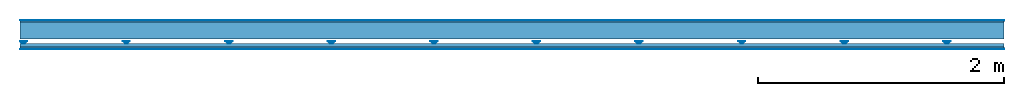
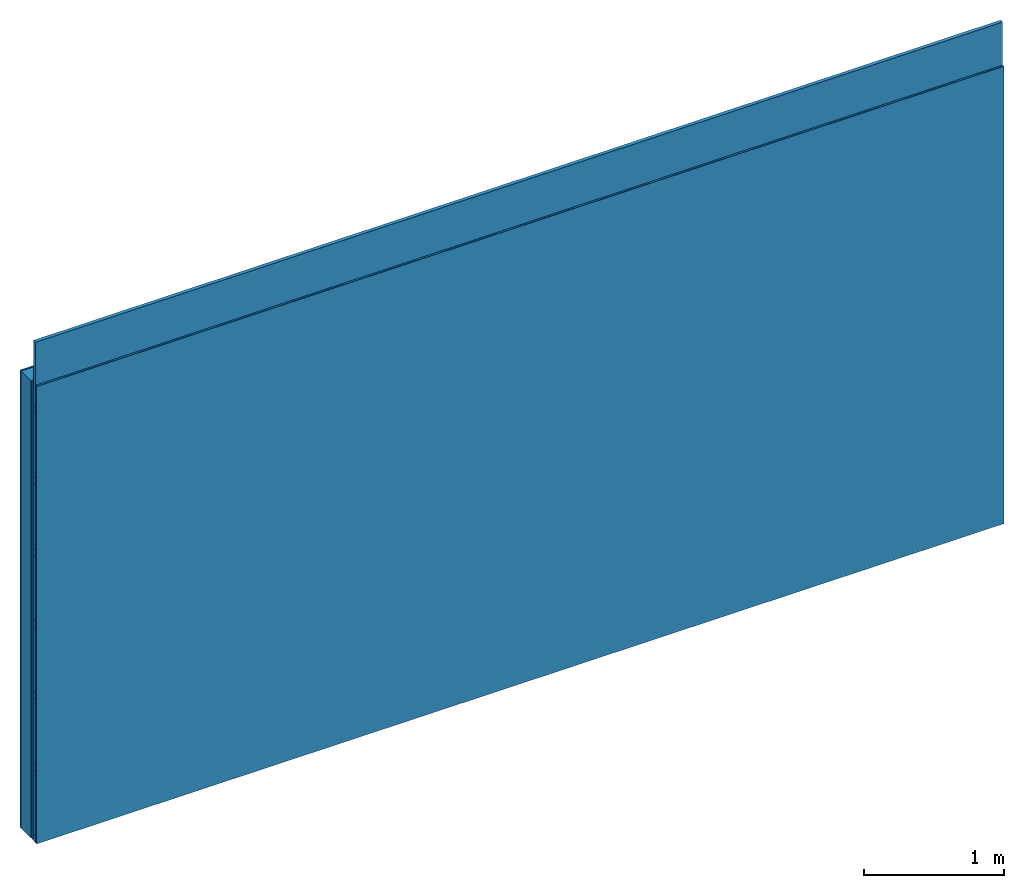
# One storey: 4 members, 4 plates, 1 element without a shape of its own.
"""IFC4 building model written with IfcOpenShell, lengths in metres."""

from ifc_helpers import new_model, si_unit, derived_unit, direction, frame, frame_2d, origin, origin_with_axes, place, context, project, spatial, polyline, rectangle, outline, extrude, material, layer, layer_set, type_object, element, aggregate, save


model = new_model("IFC4")

# Units and contexts
plan_context = context("Plan", 3, precision=1e-05, world=origin(), true_north=direction((0.0, 1.0)))
model_context = context("Model", 3, precision=1e-05, world=origin(), true_north=direction((0.0, 1.0)))
ifc_project = project(units=[si_unit("LENGTHUNIT", "METRE"), derived_unit("SOUNDPRESSUREUNIT", [(si_unit("PRESSUREUNIT", "PASCAL", prefix="MICRO"), 0)]), si_unit("ENERGYUNIT", "JOULE", prefix="MEGA"), si_unit("MASSUNIT", "GRAM", prefix="KILO"), derived_unit("THERMALTRANSMITTANCEUNIT", [(si_unit("POWERUNIT", "WATT"), 1), (si_unit("AREAUNIT", "SQUARE_METRE"), -1), (si_unit("THERMODYNAMICTEMPERATUREUNIT", "KELVIN"), -1)]), derived_unit("AREADENSITYUNIT", [(si_unit("MASSUNIT", "GRAM", prefix="KILO"), 1), (si_unit("AREAUNIT", "SQUARE_METRE"), -1)]), derived_unit("USERDEFINED", [(si_unit("ENERGYUNIT", "JOULE", prefix="MEGA"), 1), (si_unit("AREAUNIT", "SQUARE_METRE"), -1)])], contexts=[plan_context, model_context])

# Site, building, storey
site = spatial("IfcSite", under=ifc_project)
building_placement = place(None, origin())
building = spatial("IfcBuilding", under=site, at=building_placement)
storey_placement = place(building_placement, origin())
storey = spatial("IfcBuildingStorey", under=building, at=storey_placement)

# Wall, members, plates
ifc_material_1 = material(Category="04.001")
ifc_layer_1 = layer(ifc_material_1, 0.003, Name="Surface")
ifc_material_2 = material(Name="Plasterboard type A", Category="03.008")
ifc_layer_2 = layer(ifc_material_2, 0.0125, Name="1st layer")
ifc_material_3 = material(Name="of the art")
ifc_layer_3 = layer(ifc_material_3, 0.0, Name="Bond")
ifc_layer_4 = layer(None, 0.14, Name="Support")
ifc_layer_5 = layer(None, 0.036, Name="Coupling")
ifc_layer_6 = layer(None, 0.03, Name="Battens / profiles")
ifc_material_4 = material(Name="DFH2IR Knauf Diamant hard- plasterboard", Category="03.007")
ifc_layer_7 = layer(ifc_material_4, 0.015, Name="Covering 1st layer")
ifc_layer_8 = layer(ifc_material_1, 0.003, Name="Surface")
ifc_layer_set = layer_set([ifc_layer_1, ifc_layer_2, ifc_layer_3, ifc_layer_4, ifc_layer_5, ifc_layer_6, ifc_layer_7, ifc_layer_8])
wall_type = type_object("IfcWallType", Name="C0378", PredefinedType="NOTDEFINED", material=ifc_layer_set)
wall_placement = place(None, frame((0.0, 0.0, 0.0), z_axis=(0.0, -1.0, 0.0), x_axis=(1.0, 0.0, 0.0)))
wall = element("IfcWall", 1, at=wall_placement, inside=storey, type_object=wall_type, material=ifc_layer_set, Name="Wall #1")
ifc_material_5 = material(Name="Solid timber panel")
member_1_placement = place(wall_placement, origin())
member_1 = element("IfcMember", 2, at=member_1_placement, material=ifc_material_5, Name="Support", context=plan_context, shape_type="SweptSolid", body=[
    extrude(rectangle(XDim=1.0, YDim=0.14, at=frame_2d((0.5, 0.07), x_axis=(1.0, 0.0))), frame((0.0, 4.0, 0.0155), z_axis=(0.0, -1.0, 0.0), x_axis=(1.0, 0.0, 0.0)), (0.0, 0.0, 1.0), 4.0),
    extrude(rectangle(XDim=1.0, YDim=0.14, at=frame_2d((0.5, 0.07), x_axis=(1.0, 0.0))), frame((1.0, 4.0, 0.0155), z_axis=(0.0, -1.0, 0.0), x_axis=(1.0, 0.0, 0.0)), (0.0, 0.0, 1.0), 4.0),
    extrude(rectangle(XDim=1.0, YDim=0.14, at=frame_2d((0.5, 0.07), x_axis=(1.0, 0.0))), frame((2.0, 4.0, 0.0155), z_axis=(0.0, -1.0, 0.0), x_axis=(1.0, 0.0, 0.0)), (0.0, 0.0, 1.0), 4.0),
    extrude(rectangle(XDim=1.0, YDim=0.14, at=frame_2d((0.5, 0.07), x_axis=(1.0, 0.0))), frame((3.0, 4.0, 0.0155), z_axis=(0.0, -1.0, 0.0), x_axis=(1.0, 0.0, 0.0)), (0.0, 0.0, 1.0), 4.0),
    extrude(rectangle(XDim=1.0, YDim=0.14, at=frame_2d((0.5, 0.07), x_axis=(1.0, 0.0))), frame((4.0, 4.0, 0.0155), z_axis=(0.0, -1.0, 0.0), x_axis=(1.0, 0.0, 0.0)), (0.0, 0.0, 1.0), 4.0),
    extrude(rectangle(XDim=1.0, YDim=0.14, at=frame_2d((0.5, 0.07), x_axis=(1.0, 0.0))), frame((5.0, 4.0, 0.0155), z_axis=(0.0, -1.0, 0.0), x_axis=(1.0, 0.0, 0.0)), (0.0, 0.0, 1.0), 4.0),
    extrude(rectangle(XDim=1.0, YDim=0.14, at=frame_2d((0.5, 0.07), x_axis=(1.0, 0.0))), frame((6.0, 4.0, 0.0155), z_axis=(0.0, -1.0, 0.0), x_axis=(1.0, 0.0, 0.0)), (0.0, 0.0, 1.0), 4.0),
    extrude(rectangle(XDim=1.0, YDim=0.14, at=frame_2d((0.5, 0.07), x_axis=(1.0, 0.0))), frame((7.0, 4.0, 0.0155), z_axis=(0.0, -1.0, 0.0), x_axis=(1.0, 0.0, 0.0)), (0.0, 0.0, 1.0), 4.0),
])
ifc_material_6 = material()
member_2_placement = place(wall_placement, origin())
member_2 = element("IfcMember", 3, at=member_2_placement, material=ifc_material_6, Name="Coupling", context=plan_context, shape_type="SweptSolid", body=[
    extrude(outline(polyline([(0.0, 0.0), (0.06, 0.0), (0.04, 0.02), (0.02, 0.02), (0.0, 0.0)])), frame((0.0, 4.0, 0.1715), z_axis=(0.0, -1.0, 0.0), x_axis=(1.0, 0.0, 0.0)), (0.0, 0.0, 1.0), 4.0),
    extrude(outline(polyline([(0.0, 0.0), (0.06, 0.0), (0.04, 0.02), (0.02, 0.02), (0.0, 0.0)])), frame((0.834, 4.0, 0.1715), z_axis=(0.0, -1.0, 0.0), x_axis=(1.0, 0.0, 0.0)), (0.0, 0.0, 1.0), 4.0),
    extrude(outline(polyline([(0.0, 0.0), (0.06, 0.0), (0.04, 0.02), (0.02, 0.02), (0.0, 0.0)])), frame((1.668, 4.0, 0.1715), z_axis=(0.0, -1.0, 0.0), x_axis=(1.0, 0.0, 0.0)), (0.0, 0.0, 1.0), 4.0),
    extrude(outline(polyline([(0.0, 0.0), (0.06, 0.0), (0.04, 0.02), (0.02, 0.02), (0.0, 0.0)])), frame((2.502, 4.0, 0.1715), z_axis=(0.0, -1.0, 0.0), x_axis=(1.0, 0.0, 0.0)), (0.0, 0.0, 1.0), 4.0),
    extrude(outline(polyline([(0.0, 0.0), (0.06, 0.0), (0.04, 0.02), (0.02, 0.02), (0.0, 0.0)])), frame((3.336, 4.0, 0.1715), z_axis=(0.0, -1.0, 0.0), x_axis=(1.0, 0.0, 0.0)), (0.0, 0.0, 1.0), 4.0),
    extrude(outline(polyline([(0.0, 0.0), (0.06, 0.0), (0.04, 0.02), (0.02, 0.02), (0.0, 0.0)])), frame((4.17, 4.0, 0.1715), z_axis=(0.0, -1.0, 0.0), x_axis=(1.0, 0.0, 0.0)), (0.0, 0.0, 1.0), 4.0),
    extrude(outline(polyline([(0.0, 0.0), (0.06, 0.0), (0.04, 0.02), (0.02, 0.02), (0.0, 0.0)])), frame((5.004, 4.0, 0.1715), z_axis=(0.0, -1.0, 0.0), x_axis=(1.0, 0.0, 0.0)), (0.0, 0.0, 1.0), 4.0),
    extrude(outline(polyline([(0.0, 0.0), (0.06, 0.0), (0.04, 0.02), (0.02, 0.02), (0.0, 0.0)])), frame((5.838, 4.0, 0.1715), z_axis=(0.0, -1.0, 0.0), x_axis=(1.0, 0.0, 0.0)), (0.0, 0.0, 1.0), 4.0),
    extrude(outline(polyline([(0.0, 0.0), (0.06, 0.0), (0.04, 0.02), (0.02, 0.02), (0.0, 0.0)])), frame((6.672, 4.0, 0.1715), z_axis=(0.0, -1.0, 0.0), x_axis=(1.0, 0.0, 0.0)), (0.0, 0.0, 1.0), 4.0),
    extrude(outline(polyline([(0.0, 0.0), (0.06, 0.0), (0.04, 0.02), (0.02, 0.02), (0.0, 0.0)])), frame((7.506, 4.0, 0.1715), z_axis=(0.0, -1.0, 0.0), x_axis=(1.0, 0.0, 0.0)), (0.0, 0.0, 1.0), 4.0),
])
member_3_placement = place(wall_placement, origin())
member_3 = element("IfcMember", 4, at=member_3_placement, material=ifc_material_6, Name="Battens / profiles", context=plan_context, shape_type="SweptSolid", body=[
    extrude(rectangle(XDim=0.06, YDim=0.03, at=frame_2d((0.03, 0.015), x_axis=(1.0, 0.0))), frame((0.0, 0.0, 0.1915), z_axis=(1.0, 0.0, 0.0), x_axis=(0.0, 1.0, 0.0)), (0.0, 0.0, 1.0), 8.0),
    extrude(rectangle(XDim=0.06, YDim=0.03, at=frame_2d((0.03, 0.015), x_axis=(1.0, 0.0))), frame((0.0, 0.625, 0.1915), z_axis=(1.0, 0.0, 0.0), x_axis=(0.0, 1.0, 0.0)), (0.0, 0.0, 1.0), 8.0),
    extrude(rectangle(XDim=0.06, YDim=0.03, at=frame_2d((0.03, 0.015), x_axis=(1.0, 0.0))), frame((0.0, 1.25, 0.1915), z_axis=(1.0, 0.0, 0.0), x_axis=(0.0, 1.0, 0.0)), (0.0, 0.0, 1.0), 8.0),
    extrude(rectangle(XDim=0.06, YDim=0.03, at=frame_2d((0.03, 0.015), x_axis=(1.0, 0.0))), frame((0.0, 1.875, 0.1915), z_axis=(1.0, 0.0, 0.0), x_axis=(0.0, 1.0, 0.0)), (0.0, 0.0, 1.0), 8.0),
    extrude(rectangle(XDim=0.06, YDim=0.03, at=frame_2d((0.03, 0.015), x_axis=(1.0, 0.0))), frame((0.0, 2.5, 0.1915), z_axis=(1.0, 0.0, 0.0), x_axis=(0.0, 1.0, 0.0)), (0.0, 0.0, 1.0), 8.0),
    extrude(rectangle(XDim=0.06, YDim=0.03, at=frame_2d((0.03, 0.015), x_axis=(1.0, 0.0))), frame((0.0, 3.125, 0.1915), z_axis=(1.0, 0.0, 0.0), x_axis=(0.0, 1.0, 0.0)), (0.0, 0.0, 1.0), 8.0),
    extrude(rectangle(XDim=0.06, YDim=0.03, at=frame_2d((0.03, 0.015), x_axis=(1.0, 0.0))), frame((0.0, 3.75, 0.1915), z_axis=(1.0, 0.0, 0.0), x_axis=(0.0, 1.0, 0.0)), (0.0, 0.0, 1.0), 8.0),
])
ifc_material_7 = material()
member_4_placement = place(wall_placement, origin())
member_4 = element("IfcMember", 5, at=member_4_placement, material=ifc_material_7, Name="Cavity", context=plan_context, shape_type="SweptSolid", body=[
    extrude(rectangle(XDim=0.565, YDim=0.03, at=frame_2d((0.2825, 0.015), x_axis=(1.0, 0.0))), frame((0.0, 0.06, 0.1915), z_axis=(1.0, 0.0, 0.0), x_axis=(0.0, 1.0, 0.0)), (0.0, 0.0, 1.0), 8.0),
    extrude(rectangle(XDim=0.565, YDim=0.03, at=frame_2d((0.2825, 0.015), x_axis=(1.0, 0.0))), frame((0.0, 0.685, 0.1915), z_axis=(1.0, 0.0, 0.0), x_axis=(0.0, 1.0, 0.0)), (0.0, 0.0, 1.0), 8.0),
    extrude(rectangle(XDim=0.565, YDim=0.03, at=frame_2d((0.2825, 0.015), x_axis=(1.0, 0.0))), frame((0.0, 1.31, 0.1915), z_axis=(1.0, 0.0, 0.0), x_axis=(0.0, 1.0, 0.0)), (0.0, 0.0, 1.0), 8.0),
    extrude(rectangle(XDim=0.565, YDim=0.03, at=frame_2d((0.2825, 0.015), x_axis=(1.0, 0.0))), frame((0.0, 1.935, 0.1915), z_axis=(1.0, 0.0, 0.0), x_axis=(0.0, 1.0, 0.0)), (0.0, 0.0, 1.0), 8.0),
    extrude(rectangle(XDim=0.565, YDim=0.03, at=frame_2d((0.2825, 0.015), x_axis=(1.0, 0.0))), frame((0.0, 2.56, 0.1915), z_axis=(1.0, 0.0, 0.0), x_axis=(0.0, 1.0, 0.0)), (0.0, 0.0, 1.0), 8.0),
    extrude(rectangle(XDim=0.565, YDim=0.03, at=frame_2d((0.2825, 0.015), x_axis=(1.0, 0.0))), frame((0.0, 3.185, 0.1915), z_axis=(1.0, 0.0, 0.0), x_axis=(0.0, 1.0, 0.0)), (0.0, 0.0, 1.0), 8.0),
    extrude(rectangle(XDim=0.565, YDim=0.03, at=frame_2d((0.2825, 0.015), x_axis=(1.0, 0.0))), frame((0.0, 3.81, 0.1915), z_axis=(1.0, 0.0, 0.0), x_axis=(0.0, 1.0, 0.0)), (0.0, 0.0, 1.0), 8.0),
])
plate_1_placement = place(wall_placement, origin())
plate_1 = element("IfcPlate", 6, at=plate_1_placement, material=ifc_material_1, Name="Surface", context=plan_context, shape_type="SweptSolid", body=[
    extrude(rectangle(XDim=8.0, YDim=4.0, at=frame_2d((4.0, 2.0), x_axis=(1.0, 0.0))), origin_with_axes(), (0.0, 0.0, 1.0), 0.003),
])
plate_2_placement = place(wall_placement, origin())
plate_2 = element("IfcPlate", 7, at=plate_2_placement, material=ifc_material_2, Name="1st layer", context=plan_context, shape_type="SweptSolid", body=[
    extrude(rectangle(XDim=8.0, YDim=4.0, at=frame_2d((4.0, 2.0), x_axis=(1.0, 0.0))), frame((0.0, 0.0, 0.003), z_axis=(0.0, 0.0, 1.0), x_axis=(1.0, 0.0, 0.0)), (0.0, 0.0, 1.0), 0.0125),
])
plate_3_placement = place(wall_placement, origin())
plate_3 = element("IfcPlate", 8, at=plate_3_placement, material=ifc_material_4, Name="Covering 1st layer", context=plan_context, shape_type="SweptSolid", body=[
    extrude(rectangle(XDim=8.0, YDim=4.0, at=frame_2d((4.0, 2.0), x_axis=(1.0, 0.0))), frame((0.0, 0.0, 0.2215), z_axis=(0.0, 0.0, 1.0), x_axis=(1.0, 0.0, 0.0)), (0.0, 0.0, 1.0), 0.015),
])
plate_4_placement = place(wall_placement, origin())
plate_4 = element("IfcPlate", 9, at=plate_4_placement, material=ifc_material_1, Name="Surface", context=plan_context, shape_type="SweptSolid", body=[
    extrude(rectangle(XDim=8.0, YDim=4.0, at=frame_2d((4.0, 2.0), x_axis=(1.0, 0.0))), frame((0.0, 0.0, 0.2365), z_axis=(0.0, 0.0, 1.0), x_axis=(1.0, 0.0, 0.0)), (0.0, 0.0, 1.0), 0.003),
])
aggregate(wall, [plate_1, plate_2, member_1, member_2, member_3, member_4, plate_3, plate_4])

save(model, "model.ifc")
